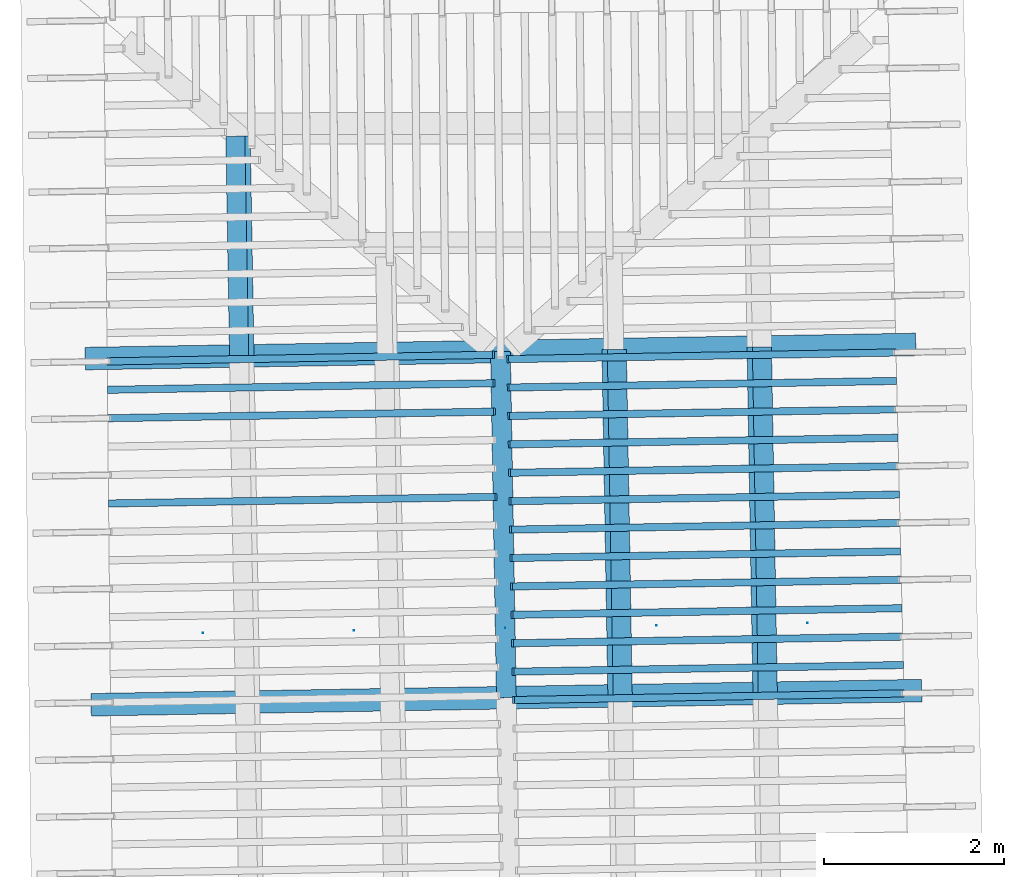
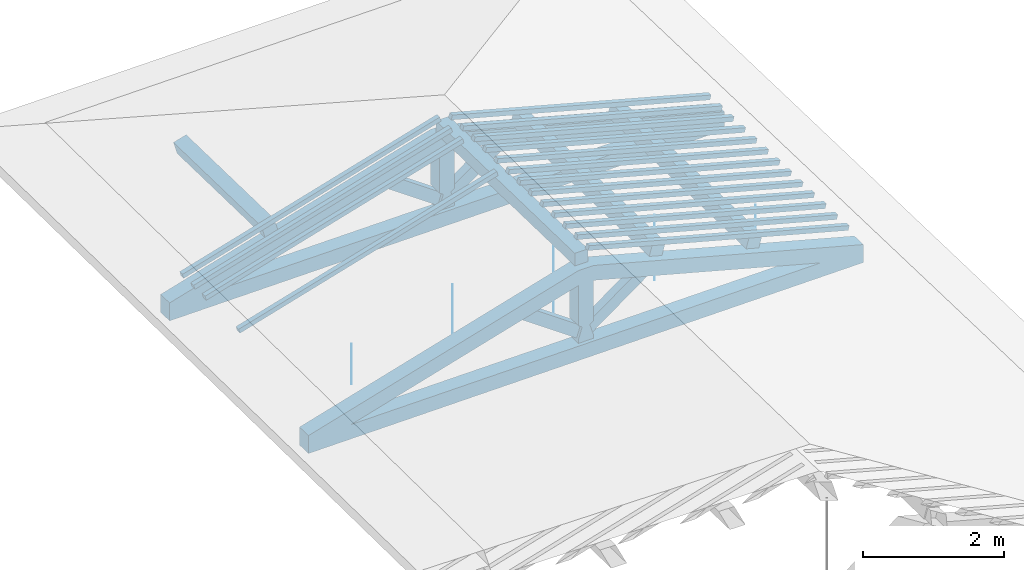
# One storey, part 6 of 19: 20 beams, 4 members, 2 elements without a shape of their own.
"""IFC4 building model written with IfcOpenShell, lengths in metres."""

import ifcopenshell
import ifcopenshell.guid

model = None  # the IFC model being written
_history = None  # IfcOwnerHistory: only IFC2X3 demands one
_inside = {}  # id of a spatial element -> (the spatial element, [elements in it])
_under = {}  # id of a project, library or spatial element -> (it, [spatial elements below it])
_declared = {}  # id of a project -> (the project, [libraries it declares])
_typed = {}  # id of a type object -> (the type object, [elements of that type])
_made_of = {}  # id of a material, layer set ... -> (it, [elements and type objects made of it])


def new_model(schema):
    """Start an empty IFC model of exactly this schema.

    Asked for "IFC4X3", IfcOpenShell would pick the latest addendum, in which some entities
    have other attributes; the version numbers below select the first issue.
    IFC2X3 requires an IfcOwnerHistory on every rooted entity: one is made here for all.
    """
    global model, _history
    if schema == "IFC4X3":
        model = ifcopenshell.file(schema_version=(4, 3, 0, 0))
    else:
        model = ifcopenshell.file(schema=schema)
    _inside.clear()
    _under.clear()
    _declared.clear()
    _typed.clear()
    _made_of.clear()
    _history = None
    if model.schema == "IFC2X3":
        org = make("IfcOrganization", Name="unknown")
        user = make(
            "IfcPersonAndOrganization",
            ThePerson=make("IfcPerson", FamilyName="unknown"),
            TheOrganization=org,
        )
        app = make(
            "IfcApplication",
            ApplicationDeveloper=org,
            Version="unknown",
            ApplicationFullName="unknown",
            ApplicationIdentifier="unknown",
        )
        _history = make(
            "IfcOwnerHistory",
            OwningUser=user,
            OwningApplication=app,
            ChangeAction="ADDED",
            CreationDate=0,
        )
    return model


def make(cls, **values):
    """One entity of the class cls with the attributes given. An attribute that is None is left unset."""
    return model.create_entity(
        cls, **{name: value for name, value in values.items() if value is not None}
    )


def entity(cls, *values):
    """Any entity or typed value of the class cls, its attributes in the order of the schema. None: left unset."""
    e = model.create_entity(cls)
    for i, value in enumerate(values):
        if value is not None:
            e[i] = value
    return e


def rooted(cls, **values):
    """An entity with a GlobalId (a new one), such as an element, a storey or a relation."""
    return make(cls, GlobalId=ifcopenshell.guid.new(), OwnerHistory=_history, **values)


def si_unit(unit_type, name, prefix=None):
    """IfcSIUnit, for example si_unit("LENGTHUNIT", "METRE", prefix="MILLI")."""
    return make("IfcSIUnit", UnitType=unit_type, Prefix=prefix, Name=name)


def converted_unit(unit_type, name, factor, base, dimensions=None, offset=None):
    """IfcConversionBasedUnit, such as the inch: factor (a typed value) times the base unit."""
    return make(
        "IfcConversionBasedUnit"
        if offset is None
        else "IfcConversionBasedUnitWithOffset",
        ConversionOffset=offset,
        Dimensions=None
        if dimensions is None
        else entity("IfcDimensionalExponents", *dimensions),
        UnitType=unit_type,
        Name=name,
        ConversionFactor=make(
            "IfcMeasureWithUnit", ValueComponent=factor, UnitComponent=base
        ),
    )


def derived_unit(unit_type, elements):
    """IfcDerivedUnit: a product of units, each with its exponent."""
    return make(
        "IfcDerivedUnit",
        Elements=[
            make("IfcDerivedUnitElement", Unit=unit, Exponent=power)
            for unit, power in elements
        ],
        UnitType=unit_type,
    )


def assignment(units):
    """IfcUnitAssignment: the units of a project."""
    return None if units is None else make("IfcUnitAssignment", Units=units)


def point(xyz):
    """IfcCartesianPoint."""
    return None if xyz is None else make("IfcCartesianPoint", Coordinates=xyz)


def direction(xyz):
    """IfcDirection."""
    return None if xyz is None else make("IfcDirection", DirectionRatios=xyz)


def frame(location, z_axis=None, x_axis=None):
    """IfcAxis2Placement3D, a coordinate frame: its origin and axes. An axis left out is left unset."""
    return make(
        "IfcAxis2Placement3D",
        Location=point(location),
        Axis=direction(z_axis),
        RefDirection=direction(x_axis),
    )


def origin():
    """The frame at (0, 0, 0) with its axes left unset."""
    return frame((0.0, 0.0, 0.0))


def place(relative_to, where):
    """IfcLocalPlacement: puts the frame where relative to a parent placement (None: the world)."""
    return make(
        "IfcLocalPlacement", PlacementRelTo=relative_to, RelativePlacement=where
    )


def context(
    kind, dimensions, precision=None, world=None, true_north=None, identifier=None
):
    """IfcGeometricRepresentationContext, for example the 3D "Model" context."""
    return make(
        "IfcGeometricRepresentationContext",
        ContextIdentifier=identifier,
        ContextType=kind,
        CoordinateSpaceDimension=dimensions,
        Precision=precision,
        WorldCoordinateSystem=world,
        TrueNorth=true_north,
    )


def subcontext(parent, identifier, kind, view, scale=None):
    """IfcGeometricRepresentationSubContext, for example "Body" below "Model"."""
    return make(
        "IfcGeometricRepresentationSubContext",
        ContextIdentifier=identifier,
        ContextType=kind,
        ParentContext=parent,
        TargetScale=scale,
        TargetView=view,
    )


def project(units=None, contexts=None):
    """IfcProject with its units and contexts."""
    return rooted(
        "IfcProject",
        Name="project",
        RepresentationContexts=contexts,
        UnitsInContext=assignment(units),
    )


def spatial(cls, under=None, at=None, **own):
    """A site, building, storey or space (cls), placed at a placement, below another one or the project."""
    s = rooted(cls, ObjectPlacement=at, **own)
    if under is not None:
        _under.setdefault(under.id(), (under, []))[1].append(s)
    return s


def point_list(points):
    """IfcCartesianPointList2D or 3D."""
    cls = (
        "IfcCartesianPointList2D" if len(points[0]) == 2 else "IfcCartesianPointList3D"
    )
    return make(cls, CoordList=points)


def arc(*indices):
    """IfcArcIndex: an arc through three numbered points of an indexed curve."""
    return model.create_entity("IfcArcIndex", indices)


def indexed_curve(points, segments=None, self_intersect=None):
    """IfcIndexedPolyCurve: lines and arcs through numbered points (the first is 1)."""
    return make(
        "IfcIndexedPolyCurve",
        Points=point_list(points),
        Segments=segments,
        SelfIntersect=self_intersect,
    )


def outline(outer, holes=None, kind="AREA"):
    """IfcArbitraryClosedProfileDef: a profile drawn as a closed curve; with holes, ...WithVoids."""
    if holes is None:
        return make("IfcArbitraryClosedProfileDef", ProfileType=kind, OuterCurve=outer)
    return make(
        "IfcArbitraryProfileDefWithVoids",
        ProfileType=kind,
        OuterCurve=outer,
        InnerCurves=holes,
    )


def extrude(swept, where, along, depth):
    """IfcExtrudedAreaSolid: the profile swept, set in the frame where, extruded along a direction by depth."""
    return make(
        "IfcExtrudedAreaSolid",
        SweptArea=swept,
        Position=where,
        ExtrudedDirection=direction(along),
        Depth=depth,
    )


def shape(context_of_items, identifier, shape_type, items):
    """IfcShapeRepresentation: the items that make up one representation, for example the "Body"."""
    return make(
        "IfcShapeRepresentation",
        ContextOfItems=context_of_items,
        RepresentationIdentifier=identifier,
        RepresentationType=shape_type,
        Items=items,
    )


def source(mapping_origin, context_of_items, identifier, shape_type, items):
    """IfcRepresentationMap: a shape defined once, which mapped items show again and again."""
    return make(
        "IfcRepresentationMap",
        MappingOrigin=mapping_origin,
        MappedRepresentation=shape(context_of_items, identifier, shape_type, items),
    )


def transform(
    local_origin,
    x_axis=None,
    y_axis=None,
    z_axis=None,
    scale=None,
    scale2=None,
    scale3=None,
    uniform=True,
):
    """IfcCartesianTransformationOperator3D, or its non-uniform kind. x_axis, y_axis, z_axis: its Axis1, 2, 3."""
    if uniform:
        return make(
            "IfcCartesianTransformationOperator3D",
            Axis1=direction(x_axis),
            Axis2=direction(y_axis),
            LocalOrigin=point(local_origin),
            Scale=scale,
            Axis3=direction(z_axis),
        )
    return make(
        "IfcCartesianTransformationOperator3DnonUniform",
        Axis1=direction(x_axis),
        Axis2=direction(y_axis),
        LocalOrigin=point(local_origin),
        Scale=scale,
        Axis3=direction(z_axis),
        Scale2=scale2,
        Scale3=scale3,
    )


def mapped(mapping_source, mapping_target):
    """IfcMappedItem: shows the shape of a source again, moved by a transform."""
    return make(
        "IfcMappedItem", MappingSource=mapping_source, MappingTarget=mapping_target
    )


def material(Name=None, Category=None):
    """IfcMaterial."""
    return make("IfcMaterial", Name=Name, Category=Category)


def made_of(thing, what):
    """Note that an element or type object is made of a material, layer set ...; save() writes the relation."""
    if what is not None:
        _made_of.setdefault(what.id(), (what, []))[1].append(thing)
    return thing


def type_object(cls, material=None, **own):
    """A type object (cls), such as IfcWallType, which elements share."""
    return made_of(rooted(cls, **own), material)


def type_shapes(of_type, sources):
    """Give a type object the sources (RepresentationMaps) that its elements show as mapped items."""
    of_type.RepresentationMaps = sources


def element(
    cls,
    number,
    at=None,
    inside=None,
    cuts=None,
    type_object=None,
    material=None,
    context=None,
    identifier="Body",
    shape_type=None,
    held_by="IfcProductDefinitionShape",
    body=None,
    shapes=None,
    **own,
):
    """One element of the class cls, such as IfcWall. Its Tag is "e" and its number.

    at: its placement. inside: the storey or other place that contains it. cuts: it is an
    opening in that element (IfcRelVoidsElement). A single representation is given by context,
    identifier, shape_type and body (its items); several are given by shapes. held_by: the class
    of the entity that holds the representations. save() writes the other relations.
    """
    e = rooted(cls, Tag="e%d" % number, ObjectPlacement=at, **own)
    if body is not None:
        shapes = [shape(context, identifier, shape_type, body)]
    if shapes is not None:
        e.Representation = make(held_by, Representations=shapes)
    if inside is not None:
        _inside.setdefault(inside.id(), (inside, []))[1].append(e)
    if cuts is not None:
        rooted(
            "IfcRelVoidsElement", RelatingBuildingElement=cuts, RelatedOpeningElement=e
        )
    if type_object is not None:
        _typed.setdefault(type_object.id(), (type_object, []))[1].append(e)
    return made_of(e, material)


def aggregate(whole, parts):
    """IfcRelAggregates: a whole, such as a stair, and the parts it consists of."""
    return rooted("IfcRelAggregates", RelatingObject=whole, RelatedObjects=parts)


def save(model, path):
    """Write the relations noted so far, then the file.

    IfcRelAggregates (storeys below a building ...), IfcRelContainedInSpatialStructure (elements
    in a storey), IfcRelDefinesByType, IfcRelAssociatesMaterial and IfcRelDeclares: one each for
    every whole, place, type object, material and project.
    """
    for whole, parts in _under.values():
        aggregate(whole, parts)
    for where, things in _inside.values():
        rooted(
            "IfcRelContainedInSpatialStructure",
            RelatedElements=things,
            RelatingStructure=where,
        )
    for kind, things in _typed.values():
        rooted("IfcRelDefinesByType", RelatedObjects=things, RelatingType=kind)
    for what, things in _made_of.values():
        rooted("IfcRelAssociatesMaterial", RelatedObjects=things, RelatingMaterial=what)
    for by, libraries in _declared.values():
        rooted("IfcRelDeclares", RelatingContext=by, RelatedDefinitions=libraries)
    model.write(path)


model = new_model("IFC4")

# Units and contexts
model_context = context("Model", 3, precision=1e-05, world=origin(), true_north=direction((6.123233995736766e-17, 1.0)))
body_context = subcontext(model_context, "Body", "Model", "MODEL_VIEW")
ifc_project = project(units=[si_unit("LENGTHUNIT", "METRE"), si_unit("AREAUNIT", "SQUARE_METRE"), si_unit("VOLUMEUNIT", "CUBIC_METRE"), converted_unit("PLANEANGLEUNIT", "DEGREE", entity("IfcPlaneAngleMeasure", 0.017453292519943278), si_unit("PLANEANGLEUNIT", "RADIAN"), dimensions=[0, 0, 0, 0, 0, 0, 0]), derived_unit("THERMALTRANSMITTANCEUNIT", [(si_unit("MASSUNIT", "GRAM", prefix="KILO"), 1), (si_unit("THERMODYNAMICTEMPERATUREUNIT", "KELVIN"), -1), (si_unit("TIMEUNIT", "SECOND"), -3)])], contexts=[model_context])

# Site, building, storey
site_placement = place(None, origin())
site = spatial("IfcSite", under=ifc_project, at=site_placement, CompositionType="ELEMENT")
building_placement = place(site_placement, origin())
building = spatial("IfcBuilding", under=site, at=building_placement, CompositionType="ELEMENT")
storey_placement = place(building_placement, frame((0.0, 0.0, 3.28)))
storey = spatial("IfcBuildingStorey", under=building, at=storey_placement, Name="Livello Copertura", CompositionType="ELEMENT", Elevation=3.28)

# Beams
ifc_material_1 = material(Name="Telaio", Category="Legno")
beam_type_1 = type_object("IfcBeamType", Name="con e 18x18 2", PredefinedType="BEAM", material=ifc_material_1)
shared_shape_1 = source(origin(), body_context, "Body", "SweptSolid", [
    extrude(outline(indexed_curve([(-0.16541753369488893, -2.7162453774766275), (0.08463069471711139, -2.716245377476629), (0.16842467663126645, 1.5495047236372541), (-0.01356084740826559, 1.9493040088108127), (-0.07407699024522271, 1.933682022505188), (-0.16541753369488893, -2.7162453774766275)], self_intersect=False)), frame((-2.713680684761416, -0.12500000000000352, 0.5116016056385222), z_axis=(0.0, 1.0, 0.0), x_axis=(0.24995178089011919, 0.0, -0.9682582853917946)), (0.0, 0.0, 1.0), 0.24999999999999992),
    extrude(outline(indexed_curve([(-2.718970219470431, -0.11203953208496607), (1.9318542149690596, -0.11203953208496614), (1.9486617037575076, -0.05184187166013539), (1.5525136616356172, 0.137960467915034), (-2.7140593608917554, 0.137960467915034), (-2.718970219470431, -0.11203953208496607)], self_intersect=False)), frame((2.7136806847614197, -0.12500000000000352, 0.5116016056385372), z_axis=(0.0, 1.0, 0.0), x_axis=(0.9631625667976574, 0.0, -0.2689198206152686)), (0.0, 0.0, 1.0), 0.24999999999999992),
    extrude(outline(indexed_curve([(-0.5601835339455478, -0.12499999999999746), (-0.49768353394554415, -0.12499999999999749), (-0.2968792817361453, -0.062499999999998515), (-0.2526268150406443, -0.12499999999999746), (0.4434537562213674, -0.12499999999999747), (0.4609040697695109, -0.06249999999999742), (0.7030153386769692, -0.12499999999999746), (0.7030153386769719, 0.1249999999999892), (0.46090406976954656, 0.06249999999999748), (0.4434537562214021, 0.12499999999999911), (-0.2526268150406462, 0.12499999999999915), (-0.29687928173614625, 0.06250000000000018), (-0.4976835339455446, 0.12499999999999908), (-0.5601835339455477, 0.12499999999999911), (-0.5601835339455478, -0.12499999999999746)], self_intersect=False)), frame((0.0, -0.12500000000000397, 0.647683533945542), z_axis=(0.0, 1.0, 0.0), x_axis=(0.0, 0.0, 1.0)), (0.0, 0.0, 1.0), 0.24999999999999992),
    extrude(outline(indexed_curve([(-4.548711713227807, -0.7192326477239056), (-4.505299668811077, -0.9654345859769559), (4.563794928678348, 0.6336914821578127), (4.520382884261614, 0.8798934204108596), (4.107604035615938, 0.7296542061691604), (3.82531022235883, 0.7573333565645375), (-3.8536390513249863, -0.5966725838775957), (-4.109441637550861, -0.7192326477239057), (-4.548711713227807, -0.7192326477239056)], self_intersect=False)), frame((0.0, -0.12500000000000175, -0.0440696120362346), z_axis=(0.0, -1.0, 0.0), x_axis=(0.984807753012208, 0.0, -0.17364817766693108)), (0.0, 0.0, -1.0), 0.24999999999999986),
    extrude(outline(indexed_curve([(0.20359543107977635, -0.4090841915047363), (0.4613119776404389, -0.4090841915047362), (-0.27535475240621304, 0.4973840166014553), (-0.3895526563140025, 0.3207843664080172), (0.20359543107977635, -0.4090841915047363)], self_intersect=False)), frame((0.5239678106288662, -0.07500000000000369, 0.5550133154913391), z_axis=(0.0, 1.0, 0.0), x_axis=(0.9631625667976574, 0.0, -0.2689198206152682)), (0.0, 0.0, 1.0), 0.14999999999999994),
    extrude(outline(indexed_curve([(-0.4613119776404252, -0.4090841915047199), (-0.20359543107976297, -0.4090841915047199), (0.38955265631398844, 0.3207843664080003), (0.2753547524061997, 0.4973840166014395), (-0.4613119776404252, -0.4090841915047199)], self_intersect=False)), frame((-0.5239678106288467, -0.07500000000000369, 0.5550133154913305), z_axis=(0.0, 1.0, 0.0), x_axis=(0.9631625667976591, 0.0, 0.2689198206152626)), (0.0, 0.0, 1.0), 0.15),
])
type_shapes(beam_type_1, [shared_shape_1])
for number, where, z_axis, x_axis, name in (
    (1, (-0.30439329114566943, 12.375094795873313, -0.3317399574950913), (0.0, 0.0, 1.0), (0.9998547813867208, 0.017041600221598438, 0.0), "con e 18x18 2"),
    (2, (-0.23882546065798543, 8.537631225652323, -0.3317557506483801), (0.0, 0.0, 1.0), (0.9998547813867208, 0.017041600221598438, 0.0), "con e 18x18 2"),
):
    element("IfcBeam", number, at=place(storey_placement, frame(where, z_axis=z_axis, x_axis=x_axis)), inside=storey, type_object=beam_type_1, material=ifc_material_1, Name=name, ObjectType="con e 18x18 2", PredefinedType="BEAM", context=body_context, shape_type="MappedRepresentation", body=[
        mapped(shared_shape_1, transform((0.0, 0.0, 0.0), scale=1.0)),
    ])

# Members
ifc_material_2 = material(Name="Legno - Legno da costruzione", Category="Legno")
member_type_1 = type_object("IfcMemberType", Name="Legno:220x220", PredefinedType="PURLIN", material=ifc_material_2)
shared_shape_2 = source(origin(), body_context, "Body", "SweptSolid", [
    extrude(outline(indexed_curve([(-1.9189999897376846, -0.11000000000000167), (1.9189999897376846, -0.11000000000000167), (1.9189999897376846, 0.11000000000000167), (-1.9189999897376846, 0.11000000000000167), (-1.9189999897376846, -0.11000000000000167)], self_intersect=False)), frame((1.0262315541353928e-08, 0.0, -0.11000000000000543), z_axis=(0.0, 0.0, 1.0), x_axis=(-1.0, 0.0, 0.0)), (0.0, 0.0, 1.0), 0.21999999999999986),
])
type_shapes(member_type_1, [shared_shape_2])
member_1_placement = place(storey_placement, frame((-0.27174431166560065, 10.456360730647422, 1.1288407383727896), z_axis=(0.0, 0.0, 1.0), x_axis=(0.017084897015610546, -0.9998540424951864, 0.0)))
element("IfcMember", 3, at=member_1_placement, inside=storey, type_object=member_type_1, material=ifc_material_2, Name="Legno:220x220", ObjectType="Legno:220x220", PredefinedType="PURLIN", context=body_context, shape_type="MappedRepresentation", body=[
    mapped(shared_shape_2, transform((0.0, 0.0, 0.0), scale=1.0)),
])
member_type_2 = type_object("IfcMemberType", Name="Legno:220x220", PredefinedType="PURLIN", material=ifc_material_2)
shared_shape_3 = source(origin(), body_context, "Body", "SweptSolid", [
    extrude(outline(indexed_curve([(-1.9189999897376846, -0.11000000000000167), (1.9189999897376846, -0.11000000000000167), (1.9189999897376846, 0.11000000000000167), (-1.9189999897376846, 0.11000000000000167), (-1.9189999897376846, -0.11000000000000167)], self_intersect=False)), frame((1.0262315541353928e-08, 0.0, -0.11000000000000543), z_axis=(0.0, 0.0, 1.0), x_axis=(-1.0, 0.0, 0.0)), (0.0, 0.0, 1.0), 0.21999999999999986),
])
type_shapes(member_type_2, [shared_shape_3])
for number, where, z_axis, x_axis, name in (
    (4, (0.9887627638023481, 10.478489498839636, 0.8161126467711997), (0.2688805697365734, 0.004594468182740752, 0.9631625667976581), (0.017084897015614553, -0.9998540424951863, 0.0), "Legno:220x220"),
    (5, (2.5968821202090817, 10.506912832072118, 0.3673377742261223), (0.2688805697365734, 0.004594468182740755, 0.9631625667976581), (0.017084897015614563, -0.9998540424951863, 0.0), "Legno:220x220"),
):
    element("IfcMember", number, at=place(storey_placement, frame(where, z_axis=z_axis, x_axis=x_axis)), inside=storey, type_object=member_type_2, material=ifc_material_2, Name=name, ObjectType="Legno:220x220", PredefinedType="PURLIN", context=body_context, shape_type="MappedRepresentation", body=[
        mapped(shared_shape_3, transform((0.0, 0.0, 0.0), scale=1.0)),
    ])
member_type_3 = type_object("IfcMemberType", Name="Legno:220x220", PredefinedType="PURLIN", material=ifc_material_2)
shared_shape_4 = source(origin(), body_context, "Body", "SweptSolid", [
    extrude(outline(indexed_curve([(-1.217832049686415, -0.11000000000000167), (1.217832049686415, -0.11000000000000167), (1.217832049686415, 0.11000000000000167), (-1.217832049686415, 0.11000000000000167), (-1.217832049686415, -0.11000000000000167)], self_intersect=False)), frame((0.700667950313585, 0.0, -0.11000000000000543), z_axis=(0.0, 0.0, 1.0), x_axis=(-1.0, 0.0, 0.0)), (0.0, 0.0, 1.0), 0.21999999999999986),
])
type_shapes(member_type_3, [shared_shape_4])
member_2_placement = place(storey_placement, frame((-3.2055006298445687, 14.244935536637126, 0.36701566136408076), z_axis=(-0.2688805697492535, -0.0045944674406682715, 0.9631625667976581), x_axis=(0.017084897015610542, -0.9998540424951863, 0.0)))
element("IfcMember", 6, at=member_2_placement, inside=storey, type_object=member_type_3, material=ifc_material_2, Name="Legno:220x220", ObjectType="Legno:220x220", PredefinedType="PURLIN", context=body_context, shape_type="MappedRepresentation", body=[
    mapped(shared_shape_4, transform((0.0, 0.0, 0.0), scale=1.0)),
])

# Beam
ifc_material_3 = material(Name="Metallo - Acciaio - 345 MPa", Category="Metallo")
beam_type_2 = type_object("IfcBeamType", Name="Porta", PredefinedType="BEAM", material=ifc_material_3)
shared_shape_5 = source(origin(), body_context, "Body", "SweptSolid", [
    extrude(outline(indexed_curve([(-0.0025, 0.0), (-9.341026746681546e-18, -0.002499999999999973), (0.0025, 0.0), (1.5308084989342274e-19, 0.002499999999999973)], segments=[arc(1, 2, 3), arc(3, 4, 1)], self_intersect=False)), frame((3.3500000000000014, 0.0, 0.01799999999999821), z_axis=(0.0, 0.0, 1.0), x_axis=(0.0, -1.0, 0.0)), (0.0, 0.0, 1.0), 0.7000000000000034),
    extrude(outline(indexed_curve([(-0.0025, 0.0), (-9.341026746681546e-18, -0.002499999999999973), (0.0025, 0.0), (1.5308084989342274e-19, 0.002499999999999973)], segments=[arc(1, 2, 3), arc(3, 4, 1)], self_intersect=False)), frame((-3.350000000000001, 0.0, 0.01799999999999821), z_axis=(0.0, 0.0, 1.0), x_axis=(0.0, -1.0, 0.0)), (0.0, 0.0, 1.0), 0.7000000000000034),
    extrude(outline(indexed_curve([(-0.0025, 0.0), (-9.341026746681546e-18, -0.002499999999999973), (0.0025, 0.0), (1.5308084989342274e-19, 0.002499999999999973)], segments=[arc(1, 2, 3), arc(3, 4, 1)], self_intersect=False)), frame((1.6750000000000014, 0.0, 0.01799999999999821), z_axis=(0.0, 0.0, 1.0), x_axis=(0.0, -1.0, 0.0)), (0.0, 0.0, 1.0), 1.1350000000000036),
    extrude(outline(indexed_curve([(-0.0025, 0.0), (-9.341026746681546e-18, -0.002499999999999973), (0.0025, 0.0), (1.5308084989342274e-19, 0.002499999999999973)], segments=[arc(1, 2, 3), arc(3, 4, 1)], self_intersect=False)), frame((-1.6749999999999987, 0.0, 0.01799999999999821), z_axis=(0.0, 0.0, 1.0), x_axis=(0.0, -1.0, 0.0)), (0.0, 0.0, 1.0), 1.1350000000000036),
    extrude(outline(indexed_curve([(-0.0025, 4.038861436081489e-18), (-1.8222810943682823e-17, -0.0025000000000000044), (0.0025, -4.0388614360814286e-18), (3.483749923768857e-18, 0.0024999999999999957)], segments=[arc(1, 2, 3), arc(3, 4, 1)], self_intersect=False)), frame((0.0, 0.0, 0.017999999999998344), z_axis=(0.0, 0.0, 1.0), x_axis=(0.0, -1.0, 0.0)), (0.0, 0.0, 1.0), 1.350000000000003),
])
type_shapes(beam_type_2, [shared_shape_5])
beam_1_placement = place(storey_placement, frame((-0.2517358920956677, 9.30981008036948, -0.3492000000000056), z_axis=(0.0, 0.0, 1.0), x_axis=(0.9998547874088545, 0.017041246890830943, 0.0)))
element("IfcBeam", 7, at=beam_1_placement, inside=storey, type_object=beam_type_2, material=ifc_material_3, Name="Porta", ObjectType="Porta", PredefinedType="BEAM", context=body_context, shape_type="MappedRepresentation", body=[
    mapped(shared_shape_5, transform((0.0, 0.0, 0.0), scale=1.0)),
])

# Assembly, beams
assembly_1_placement = place(storey_placement, origin())
assembly_1 = element("IfcElementAssembly", 8, at=assembly_1_placement, inside=storey, Name="Sistema di travi strutturali:Sistema di travi strutturali", ObjectType="Sistema di travi strutturali:Sistema di travi strutturali", AssemblyPlace="NOTDEFINED", PredefinedType="BEAM_GRID")
beam_type_3 = type_object("IfcBeamType", Name="Legno:80x80", PredefinedType="JOIST", material=ifc_material_2)
shared_shape_6 = source(origin(), body_context, "Body", "SweptSolid", [
    extrude(outline(indexed_curve([(-2.2175, -0.04000000000000169), (2.2175, -0.04000000000000169), (2.2175, 0.04000000000000169), (-2.2175, 0.04000000000000169), (-2.2175, -0.04000000000000169)], self_intersect=False)), frame((0.0, 0.0, -0.040000000000005476), z_axis=(0.0, 0.0, 1.0), x_axis=(-1.0, 0.0, 0.0)), (0.0, 0.0, 1.0), 0.07999999999999997),
])
type_shapes(beam_type_3, [shared_shape_6])
beam_2_placement = place(assembly_1_placement, frame((-2.5183852936405335, 12.302235933675151, 0.7051180813762467), z_axis=(-0.2688805697492536, -0.004594467440668279, 0.9631625667976583), x_axis=(0.9630219859926786, 0.016455533263027025, 0.26891982061526554)))
beam_2 = element("IfcBeam", 9, at=beam_2_placement, type_object=beam_type_3, material=ifc_material_2, Name="Legno:80x80", ObjectType="Legno:80x80", PredefinedType="JOIST", context=body_context, shape_type="MappedRepresentation", body=[
    mapped(shared_shape_6, transform((0.0, 0.0, 0.0), scale=1.0)),
])
beam_type_4 = type_object("IfcBeamType", Name="Legno:80x80", PredefinedType="JOIST", material=ifc_material_2)
shared_shape_7 = source(origin(), body_context, "Body", "SweptSolid", [
    extrude(outline(indexed_curve([(-2.2185, -0.04000000000000169), (2.2185, -0.04000000000000169), (2.2185, 0.04000000000000169), (-2.2185, 0.04000000000000169), (-2.2185, -0.04000000000000169)], self_intersect=False)), frame((0.0, 0.0, -0.040000000000005476), z_axis=(0.0, 0.0, 1.0), x_axis=(-1.0, 0.0, 0.0)), (0.0, 0.0, 1.0), 0.07999999999999997),
])
type_shapes(beam_type_4, [shared_shape_7])
beam_3_placement = place(assembly_1_placement, frame((-2.5141508306058675, 11.987262306275278, 0.7047977084163208), z_axis=(-0.2688805697492535, -0.004594467440668278, 0.9631625667976583), x_axis=(0.9630219859926786, 0.01645553326302703, 0.2689198206152654)))
beam_3 = element("IfcBeam", 10, at=beam_3_placement, type_object=beam_type_4, material=ifc_material_2, Name="Legno:80x80", ObjectType="Legno:80x80", PredefinedType="JOIST", context=body_context, shape_type="MappedRepresentation", body=[
    mapped(shared_shape_7, transform((0.0, 0.0, 0.0), scale=1.0)),
])
beam_type_5 = type_object("IfcBeamType", Name="Legno:80x80", PredefinedType="JOIST", material=ifc_material_2)
shared_shape_8 = source(origin(), body_context, "Body", "SweptSolid", [
    extrude(outline(indexed_curve([(-2.2195, -0.04000000000000169), (2.2195, -0.04000000000000169), (2.2195, 0.04000000000000169), (-2.2195, 0.04000000000000169), (-2.2195, -0.04000000000000169)], self_intersect=False)), frame((0.0, 0.0, -0.040000000000005476), z_axis=(0.0, 0.0, 1.0), x_axis=(-1.0, 0.0, 0.0)), (0.0, 0.0, 1.0), 0.07999999999999997),
])
type_shapes(beam_type_5, [shared_shape_8])
beam_4_placement = place(assembly_1_placement, frame((-2.509916367571202, 11.672288678875406, 0.704477335456395), z_axis=(-0.26888056974925356, -0.004594467440668278, 0.9631625667976582), x_axis=(0.9630219859926786, 0.01645553326302703, 0.2689198206152655)))
beam_4 = element("IfcBeam", 11, at=beam_4_placement, type_object=beam_type_5, material=ifc_material_2, Name="Legno:80x80", ObjectType="Legno:80x80", PredefinedType="JOIST", context=body_context, shape_type="MappedRepresentation", body=[
    mapped(shared_shape_8, transform((0.0, 0.0, 0.0), scale=1.0)),
])
beam_type_6 = type_object("IfcBeamType", Name="Legno:80x80", PredefinedType="JOIST", material=ifc_material_2)
shared_shape_9 = source(origin(), body_context, "Body", "SweptSolid", [
    extrude(outline(indexed_curve([(-2.2235, -0.04000000000000169), (2.2235, -0.04000000000000169), (2.2235, 0.04000000000000169), (-2.2235, 0.04000000000000169), (-2.2235, -0.04000000000000169)], self_intersect=False)), frame((0.0, 0.0, -0.040000000000005476), z_axis=(0.0, 0.0, 1.0), x_axis=(-1.0, 0.0, 0.0)), (0.0, 0.0, 1.0), 0.07999999999999997),
])
type_shapes(beam_type_6, [shared_shape_9])
beam_5_placement = place(assembly_1_placement, frame((-2.497212978467208, 10.727367796675784, 0.7035162165766167), z_axis=(-0.26888056974925356, -0.0045944674406682776, 0.9631625667976583), x_axis=(0.9630219859926786, 0.016455533263027053, 0.2689198206152655)))
beam_5 = element("IfcBeam", 12, at=beam_5_placement, type_object=beam_type_6, material=ifc_material_2, Name="Legno:80x80", ObjectType="Legno:80x80", PredefinedType="JOIST", context=body_context, shape_type="MappedRepresentation", body=[
    mapped(shared_shape_9, transform((0.0, 0.0, 0.0), scale=1.0)),
])
aggregate(assembly_1, [beam_2, beam_3, beam_4, beam_5])

assembly_2_placement = place(storey_placement, origin())
assembly_2 = element("IfcElementAssembly", 13, at=assembly_2_placement, inside=storey, Name="Sistema di travi strutturali:Sistema di travi strutturali", ObjectType="Sistema di travi strutturali:Sistema di travi strutturali", AssemblyPlace="NOTDEFINED", PredefinedType="BEAM_GRID")
beam_type_7 = type_object("IfcBeamType", Name="Legno:80x80", PredefinedType="JOIST", material=ifc_material_2)
shared_shape_10 = source(origin(), body_context, "Body", "SweptSolid", [
    extrude(outline(indexed_curve([(-2.229, -0.04000000000000169), (2.229, -0.04000000000000169), (2.229, 0.04000000000000169), (-2.229, 0.04000000000000169), (-2.229, -0.04000000000000169)], self_intersect=False)), frame((0.0, 0.0, -0.040000000000005476), z_axis=(0.0, 0.0, 1.0), x_axis=(-1.0, 0.0, 0.0)), (0.0, 0.0, 1.0), 0.07999999999999997),
])
type_shapes(beam_type_7, [shared_shape_10])
beam_6_placement = place(assembly_2_placement, frame((1.9227690127595285, 12.327213477765303, 0.7021381827460654), z_axis=(0.2688805697492535, 0.004594467440668275, 0.9631625667976582), x_axis=(-0.9630219859926786, -0.016455533263027847, 0.2689198206152654)))
beam_6 = element("IfcBeam", 14, at=beam_6_placement, type_object=beam_type_7, material=ifc_material_2, Name="Legno:80x80", ObjectType="Legno:80x80", PredefinedType="JOIST", context=body_context, shape_type="MappedRepresentation", body=[
    mapped(shared_shape_10, transform((0.0, 0.0, 0.0), scale=1.0)),
])
beam_type_8 = type_object("IfcBeamType", Name="Legno:80x80", PredefinedType="JOIST", material=ifc_material_2)
shared_shape_11 = source(origin(), body_context, "Body", "SweptSolid", [
    extrude(outline(indexed_curve([(-2.2365, -0.04000000000000169), (2.2365, -0.04000000000000169), (2.2365, 0.04000000000000169), (-2.2365, 0.04000000000000169), (-2.2365, -0.04000000000000169)], self_intersect=False)), frame((0.0, 0.0, -0.040000000000005476), z_axis=(0.0, 0.0, 1.0), x_axis=(-1.0, 0.0, 0.0)), (0.0, 0.0, 1.0), 0.07999999999999997),
])
type_shapes(beam_type_8, [shared_shape_11])
beam_7_placement = place(assembly_2_placement, frame((1.967520977221794, 10.122656288802869, 0.700161187852499), z_axis=(0.26888056974925345, 0.004594467440668276, 0.9631625667976583), x_axis=(-0.9630219859926786, -0.01645553326302763, 0.26891982061526537)))
beam_7 = element("IfcBeam", 15, at=beam_7_placement, type_object=beam_type_8, material=ifc_material_2, Name="Legno:80x80", ObjectType="Legno:80x80", PredefinedType="JOIST", context=body_context, shape_type="MappedRepresentation", body=[
    mapped(shared_shape_11, transform((0.0, 0.0, 0.0), scale=1.0)),
])
beam_type_9 = type_object("IfcBeamType", Name="Legno:80x80", PredefinedType="JOIST", material=ifc_material_2)
shared_shape_12 = source(origin(), body_context, "Body", "SweptSolid", [
    extrude(outline(indexed_curve([(-2.2375, -0.04000000000000169), (2.2375, -0.04000000000000169), (2.2375, 0.04000000000000169), (-2.2375, 0.04000000000000169), (-2.2375, -0.04000000000000169)], self_intersect=False)), frame((0.0, 0.0, -0.040000000000005476), z_axis=(0.0, 0.0, 1.0), x_axis=(-1.0, 0.0, 0.0)), (0.0, 0.0, 1.0), 0.07999999999999997),
])
type_shapes(beam_type_9, [shared_shape_12])
beam_8_placement = place(assembly_2_placement, frame((1.9739141150021176, 9.807719547522519, 0.6998787600105612), z_axis=(0.2688805697492534, 0.004594467440668277, 0.9631625667976583), x_axis=(-0.9630219859926786, -0.01645553326302787, 0.2689198206152653)))
beam_8 = element("IfcBeam", 16, at=beam_8_placement, type_object=beam_type_9, material=ifc_material_2, Name="Legno:80x80", ObjectType="Legno:80x80", PredefinedType="JOIST", context=body_context, shape_type="MappedRepresentation", body=[
    mapped(shared_shape_12, transform((0.0, 0.0, 0.0), scale=1.0)),
])
beam_type_10 = type_object("IfcBeamType", Name="Legno:80x80", PredefinedType="JOIST", material=ifc_material_2)
shared_shape_13 = source(origin(), body_context, "Body", "SweptSolid", [
    extrude(outline(indexed_curve([(-2.2415000000000003, -0.04000000000000169), (2.2415000000000003, -0.04000000000000169), (2.2415000000000003, 0.04000000000000169), (-2.2415000000000003, 0.04000000000000169), (-2.2415000000000003, -0.04000000000000169)], self_intersect=False)), frame((0.0, 0.0, -0.040000000000005476), z_axis=(0.0, 0.0, 1.0), x_axis=(-1.0, 0.0, 0.0)), (0.0, 0.0, 1.0), 0.07999999999999997),
])
type_shapes(beam_type_10, [shared_shape_13])
beam_9_placement = place(assembly_2_placement, frame((1.9994866661234127, 8.547972582401126, 0.6987490486428086), z_axis=(0.2688805697492535, 0.004594467440668277, 0.9631625667976583), x_axis=(-0.9630219859926786, -0.016455533263027882, 0.2689198206152654)))
beam_9 = element("IfcBeam", 17, at=beam_9_placement, type_object=beam_type_10, material=ifc_material_2, Name="Legno:80x80", ObjectType="Legno:80x80", PredefinedType="JOIST", context=body_context, shape_type="MappedRepresentation", body=[
    mapped(shared_shape_13, transform((0.0, 0.0, 0.0), scale=1.0)),
])
beam_type_11 = type_object("IfcBeamType", Name="Legno:80x80", PredefinedType="JOIST", material=ifc_material_2)
shared_shape_14 = source(origin(), body_context, "Body", "SweptSolid", [
    extrude(outline(indexed_curve([(-2.2405000000000004, -0.04000000000000169), (2.2405000000000004, -0.04000000000000169), (2.2405000000000004, 0.04000000000000169), (-2.2405000000000004, 0.04000000000000169), (-2.2405000000000004, -0.04000000000000169)], self_intersect=False)), frame((0.0, 0.0, -0.040000000000005476), z_axis=(0.0, 0.0, 1.0), x_axis=(-1.0, 0.0, 0.0)), (0.0, 0.0, 1.0), 0.07999999999999997),
])
type_shapes(beam_type_11, [shared_shape_14])
beam_10_placement = place(assembly_2_placement, frame((1.9930935283430886, 8.862909323681473, 0.6990314764847474), z_axis=(0.2688805697492535, 0.004594467440668276, 0.9631625667976582), x_axis=(-0.9630219859926786, -0.01645553326302788, 0.2689198206152654)))
beam_10 = element("IfcBeam", 18, at=beam_10_placement, type_object=beam_type_11, material=ifc_material_2, Name="Legno:80x80", ObjectType="Legno:80x80", PredefinedType="JOIST", context=body_context, shape_type="MappedRepresentation", body=[
    mapped(shared_shape_14, transform((0.0, 0.0, 0.0), scale=1.0)),
])
beam_type_12 = type_object("IfcBeamType", Name="Legno:80x80", PredefinedType="JOIST", material=ifc_material_2)
shared_shape_15 = source(origin(), body_context, "Body", "SweptSolid", [
    extrude(outline(indexed_curve([(-2.2395, -0.04000000000000169), (2.2395, -0.04000000000000169), (2.2395, 0.04000000000000169), (-2.2395, 0.04000000000000169), (-2.2395, -0.04000000000000169)], self_intersect=False)), frame((0.0, 0.0, -0.040000000000005476), z_axis=(0.0, 0.0, 1.0), x_axis=(-1.0, 0.0, 0.0)), (0.0, 0.0, 1.0), 0.07999999999999997),
])
type_shapes(beam_type_12, [shared_shape_15])
beam_11_placement = place(assembly_2_placement, frame((1.9867003905627647, 9.177846064961821, 0.6993139043266854), z_axis=(0.2688805697492535, 0.004594467440668277, 0.9631625667976583), x_axis=(-0.9630219859926786, -0.01645553326302788, 0.2689198206152654)))
beam_11 = element("IfcBeam", 19, at=beam_11_placement, type_object=beam_type_12, material=ifc_material_2, Name="Legno:80x80", ObjectType="Legno:80x80", PredefinedType="JOIST", context=body_context, shape_type="MappedRepresentation", body=[
    mapped(shared_shape_15, transform((0.0, 0.0, 0.0), scale=1.0)),
])
beam_type_13 = type_object("IfcBeamType", Name="Legno:80x80", PredefinedType="JOIST", material=ifc_material_2)
shared_shape_16 = source(origin(), body_context, "Body", "SweptSolid", [
    extrude(outline(indexed_curve([(-2.2385, -0.04000000000000169), (2.2385, -0.04000000000000169), (2.2385, 0.04000000000000169), (-2.2385, 0.04000000000000169), (-2.2385, -0.04000000000000169)], self_intersect=False)), frame((0.0, 0.0, -0.040000000000005476), z_axis=(0.0, 0.0, 1.0), x_axis=(-1.0, 0.0, 0.0)), (0.0, 0.0, 1.0), 0.07999999999999997),
])
type_shapes(beam_type_13, [shared_shape_16])
beam_12_placement = place(assembly_2_placement, frame((1.9803072527824415, 9.492782806242172, 0.6995963321686229), z_axis=(0.26888056974925345, 0.0045944674406682776, 0.9631625667976583), x_axis=(-0.9630219859926786, -0.016455533263027875, 0.26891982061526537)))
beam_12 = element("IfcBeam", 20, at=beam_12_placement, type_object=beam_type_13, material=ifc_material_2, Name="Legno:80x80", ObjectType="Legno:80x80", PredefinedType="JOIST", context=body_context, shape_type="MappedRepresentation", body=[
    mapped(shared_shape_16, transform((0.0, 0.0, 0.0), scale=1.0)),
])
beam_type_14 = type_object("IfcBeamType", Name="Legno:80x80", PredefinedType="JOIST", material=ifc_material_2)
shared_shape_17 = source(origin(), body_context, "Body", "SweptSolid", [
    extrude(outline(indexed_curve([(-2.2355, -0.04000000000000169), (2.2355, -0.04000000000000169), (2.2355, 0.04000000000000169), (-2.2355, 0.04000000000000169), (-2.2355, -0.04000000000000169)], self_intersect=False)), frame((0.0, 0.0, -0.040000000000005476), z_axis=(0.0, 0.0, 1.0), x_axis=(-1.0, 0.0, 0.0)), (0.0, 0.0, 1.0), 0.07999999999999997),
])
type_shapes(beam_type_14, [shared_shape_17])
beam_13_placement = place(assembly_2_placement, frame((1.9611278394414706, 10.437593030083214, 0.7004436156944366), z_axis=(0.26888056974925345, 0.0045944674406682776, 0.9631625667976583), x_axis=(-0.9630219859926786, -0.01645553326302787, 0.26891982061526537)))
beam_13 = element("IfcBeam", 21, at=beam_13_placement, type_object=beam_type_14, material=ifc_material_2, Name="Legno:80x80", ObjectType="Legno:80x80", PredefinedType="JOIST", context=body_context, shape_type="MappedRepresentation", body=[
    mapped(shared_shape_17, transform((0.0, 0.0, 0.0), scale=1.0)),
])
beam_type_15 = type_object("IfcBeamType", Name="Legno:80x80", PredefinedType="JOIST", material=ifc_material_2)
shared_shape_18 = source(origin(), body_context, "Body", "SweptSolid", [
    extrude(outline(indexed_curve([(-2.2345, -0.04000000000000169), (2.2345, -0.04000000000000169), (2.2345, 0.04000000000000169), (-2.2345, 0.04000000000000169), (-2.2345, -0.04000000000000169)], self_intersect=False)), frame((0.0, 0.0, -0.040000000000005476), z_axis=(0.0, 0.0, 1.0), x_axis=(-1.0, 0.0, 0.0)), (0.0, 0.0, 1.0), 0.07999999999999997),
])
type_shapes(beam_type_15, [shared_shape_18])
beam_14_placement = place(assembly_2_placement, frame((1.9547347016611463, 10.752529771363566, 0.7007260435363751), z_axis=(0.26888056974925356, 0.0045944674406682776, 0.9631625667976583), x_axis=(-0.9630219859926786, -0.016455533263027622, 0.2689198206152655)))
beam_14 = element("IfcBeam", 22, at=beam_14_placement, type_object=beam_type_15, material=ifc_material_2, Name="Legno:80x80", ObjectType="Legno:80x80", PredefinedType="JOIST", context=body_context, shape_type="MappedRepresentation", body=[
    mapped(shared_shape_18, transform((0.0, 0.0, 0.0), scale=1.0)),
])
beam_type_16 = type_object("IfcBeamType", Name="Legno:80x80", PredefinedType="JOIST", material=ifc_material_2)
shared_shape_19 = source(origin(), body_context, "Body", "SweptSolid", [
    extrude(outline(indexed_curve([(-2.2335000000000003, -0.04000000000000169), (2.2335000000000003, -0.04000000000000169), (2.2335000000000003, 0.04000000000000169), (-2.2335000000000003, 0.04000000000000169), (-2.2335000000000003, -0.04000000000000169)], self_intersect=False)), frame((0.0, 0.0, -0.040000000000005476), z_axis=(0.0, 0.0, 1.0), x_axis=(-1.0, 0.0, 0.0)), (0.0, 0.0, 1.0), 0.07999999999999997),
])
type_shapes(beam_type_16, [shared_shape_19])
beam_15_placement = place(assembly_2_placement, frame((1.9483415638808226, 11.067466512643911, 0.7010084713783135), z_axis=(0.2688805697492534, 0.004594467440668276, 0.9631625667976583), x_axis=(-0.9630219859926786, -0.01645553326302786, 0.2689198206152653)))
beam_15 = element("IfcBeam", 23, at=beam_15_placement, type_object=beam_type_16, material=ifc_material_2, Name="Legno:80x80", ObjectType="Legno:80x80", PredefinedType="JOIST", context=body_context, shape_type="MappedRepresentation", body=[
    mapped(shared_shape_19, transform((0.0, 0.0, 0.0), scale=1.0)),
])
beam_type_17 = type_object("IfcBeamType", Name="Legno:80x80", PredefinedType="JOIST", material=ifc_material_2)
shared_shape_20 = source(origin(), body_context, "Body", "SweptSolid", [
    extrude(outline(indexed_curve([(-2.232, -0.04000000000000169), (2.232, -0.04000000000000169), (2.232, 0.04000000000000169), (-2.232, 0.04000000000000169), (-2.232, -0.04000000000000169)], self_intersect=False)), frame((0.0, 0.0, -0.040000000000005476), z_axis=(0.0, 0.0, 1.0), x_axis=(-1.0, 0.0, 0.0)), (0.0, 0.0, 1.0), 0.07999999999999997),
])
type_shapes(beam_type_17, [shared_shape_20])
beam_16_placement = place(assembly_2_placement, frame((1.9419484261004991, 11.382403253924263, 0.7012908992202512), z_axis=(0.2688805697492535, 0.0045944674406682776, 0.9631625667976583), x_axis=(-0.9630219859926786, -0.01645553326302761, 0.2689198206152654)))
beam_16 = element("IfcBeam", 24, at=beam_16_placement, type_object=beam_type_17, material=ifc_material_2, Name="Legno:80x80", ObjectType="Legno:80x80", PredefinedType="JOIST", context=body_context, shape_type="MappedRepresentation", body=[
    mapped(shared_shape_20, transform((0.0, 0.0, 0.0), scale=1.0)),
])
beam_type_18 = type_object("IfcBeamType", Name="Legno:80x80", PredefinedType="JOIST", material=ifc_material_2)
shared_shape_21 = source(origin(), body_context, "Body", "SweptSolid", [
    extrude(outline(indexed_curve([(-2.2310000000000003, -0.04000000000000169), (2.2310000000000003, -0.04000000000000169), (2.2310000000000003, 0.04000000000000169), (-2.2310000000000003, 0.04000000000000169), (-2.2310000000000003, -0.04000000000000169)], self_intersect=False)), frame((0.0, 0.0, -0.040000000000005476), z_axis=(0.0, 0.0, 1.0), x_axis=(-1.0, 0.0, 0.0)), (0.0, 0.0, 1.0), 0.07999999999999997),
])
type_shapes(beam_type_18, [shared_shape_21])
beam_17_placement = place(assembly_2_placement, frame((1.9355552883201756, 11.697339995204608, 0.7015733270621897), z_axis=(0.26888056974925345, 0.004594467440668276, 0.9631625667976583), x_axis=(-0.9630219859926786, -0.016455533263027847, 0.26891982061526537)))
beam_17 = element("IfcBeam", 25, at=beam_17_placement, type_object=beam_type_18, material=ifc_material_2, Name="Legno:80x80", ObjectType="Legno:80x80", PredefinedType="JOIST", context=body_context, shape_type="MappedRepresentation", body=[
    mapped(shared_shape_21, transform((0.0, 0.0, 0.0), scale=1.0)),
])
beam_type_19 = type_object("IfcBeamType", Name="Legno:80x80", PredefinedType="JOIST", material=ifc_material_2)
shared_shape_22 = source(origin(), body_context, "Body", "SweptSolid", [
    extrude(outline(indexed_curve([(-2.23, -0.04000000000000169), (2.23, -0.04000000000000169), (2.23, 0.04000000000000169), (-2.23, 0.04000000000000169), (-2.23, -0.04000000000000169)], self_intersect=False)), frame((0.0, 0.0, -0.040000000000005476), z_axis=(0.0, 0.0, 1.0), x_axis=(-1.0, 0.0, 0.0)), (0.0, 0.0, 1.0), 0.07999999999999997),
])
type_shapes(beam_type_19, [shared_shape_22])
beam_18_placement = place(assembly_2_placement, frame((1.9291621505398522, 12.01227673648496, 0.7018557549041274), z_axis=(0.2688805697492534, 0.004594467440668277, 0.9631625667976583), x_axis=(-0.9630219859926786, -0.016455533263027608, 0.2689198206152653)))
beam_18 = element("IfcBeam", 26, at=beam_18_placement, type_object=beam_type_19, material=ifc_material_2, Name="Legno:80x80", ObjectType="Legno:80x80", PredefinedType="JOIST", context=body_context, shape_type="MappedRepresentation", body=[
    mapped(shared_shape_22, transform((0.0, 0.0, 0.0), scale=1.0)),
])
aggregate(assembly_2, [beam_9, beam_10, beam_11, beam_12, beam_8, beam_7, beam_13, beam_14, beam_15, beam_16, beam_17, beam_18, beam_6])

save(model, "model.ifc")
